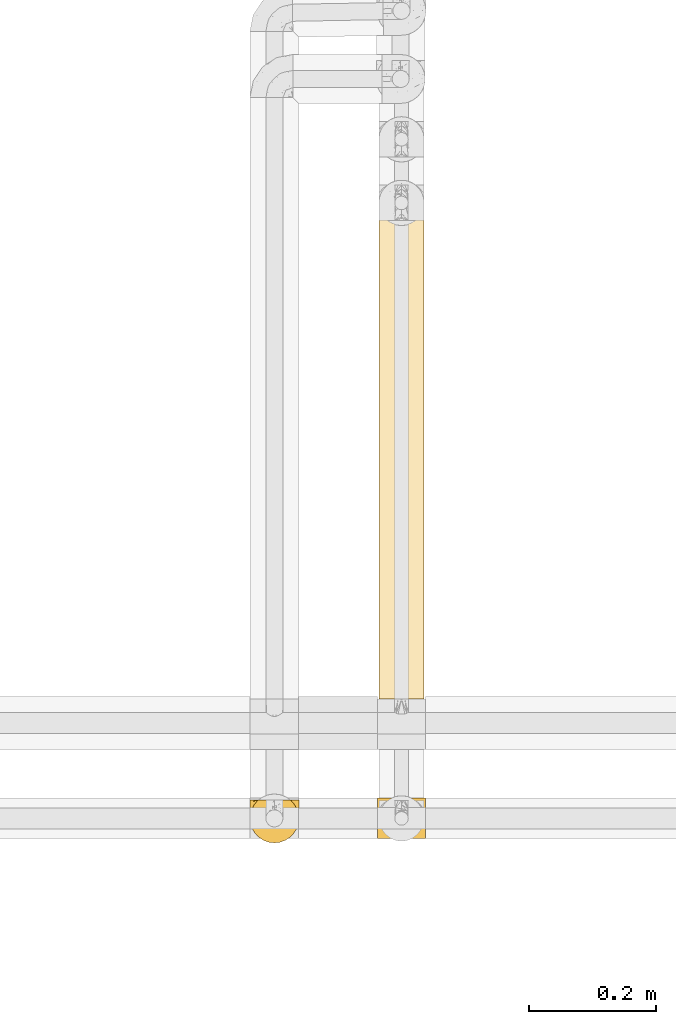
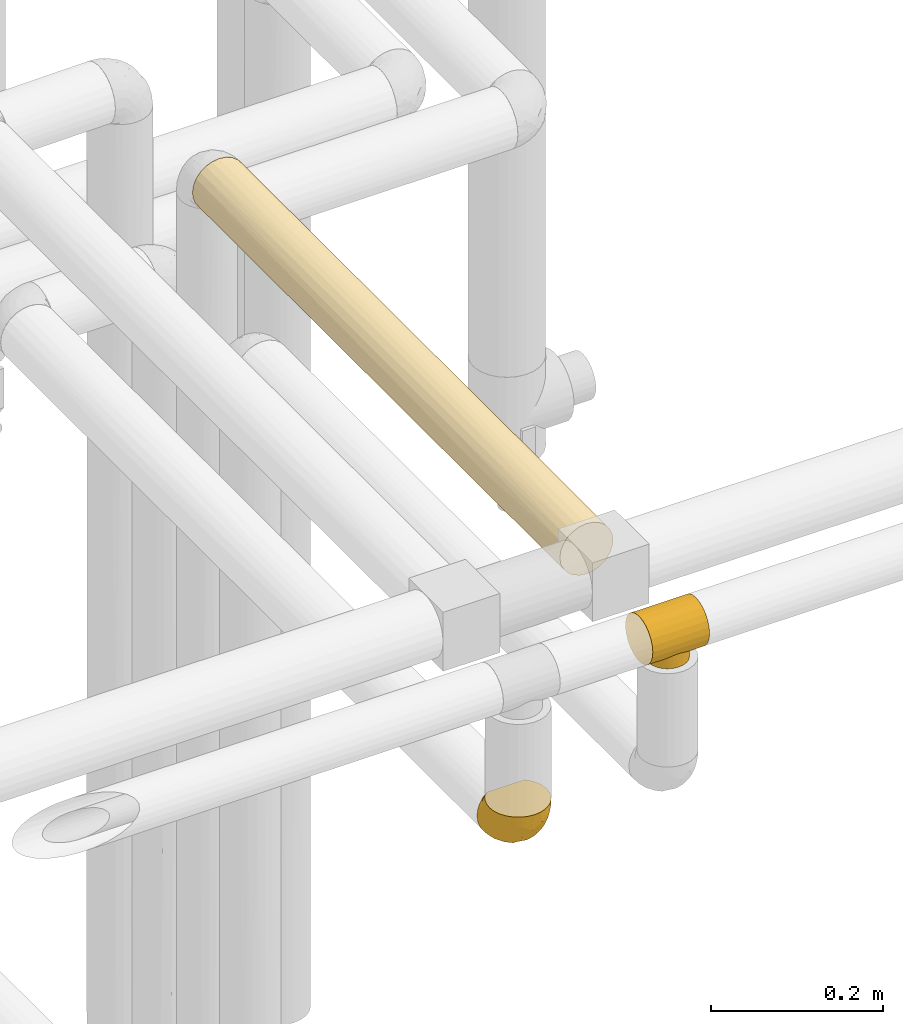
# One storey, part 54 of 827: 3 coverings.
"""IFC2X3 building model written with IfcOpenShell, lengths in millimetres."""

from ifc_helpers import new_model, entity, si_unit, converted_unit, derived_unit, direction, frame, origin, place, context, subcontext, project, spatial, faceted_brep, element, save


model = new_model("IFC2X3")

# Units and contexts
model_context = context("Model", 3, precision=0.01, world=origin(), true_north=direction((6.12303176911189e-17, 1.0)))
body_context = subcontext(model_context, "Body", "Model", "MODEL_VIEW")
ifc_project = project(units=[si_unit("LENGTHUNIT", "METRE", prefix="MILLI"), si_unit("AREAUNIT", "SQUARE_METRE"), si_unit("VOLUMEUNIT", "CUBIC_METRE"), converted_unit("PLANEANGLEUNIT", "DEGREE", entity("IfcRatioMeasure", 0.0174532925199433), si_unit("PLANEANGLEUNIT", "RADIAN"), dimensions=[0, 0, 0, 0, 0, 0, 0]), si_unit("MASSUNIT", "GRAM", prefix="KILO"), derived_unit("MASSDENSITYUNIT", [(si_unit("MASSUNIT", "GRAM", prefix="KILO"), 1), (si_unit("LENGTHUNIT", "METRE"), -3)]), derived_unit("MOMENTOFINERTIAUNIT", [(si_unit("LENGTHUNIT", "METRE"), 4)]), si_unit("TIMEUNIT", "SECOND"), si_unit("FREQUENCYUNIT", "HERTZ"), si_unit("THERMODYNAMICTEMPERATUREUNIT", "DEGREE_CELSIUS"), derived_unit("THERMALTRANSMITTANCEUNIT", [(si_unit("MASSUNIT", "GRAM", prefix="KILO"), 1), (si_unit("THERMODYNAMICTEMPERATUREUNIT", "KELVIN"), -1), (si_unit("TIMEUNIT", "SECOND"), -3)]), derived_unit("VOLUMETRICFLOWRATEUNIT", [(si_unit("LENGTHUNIT", "METRE"), 3), (si_unit("TIMEUNIT", "SECOND"), -1)]), derived_unit("MASSFLOWRATEUNIT", [(si_unit("MASSUNIT", "GRAM", prefix="KILO"), 1), (si_unit("TIMEUNIT", "SECOND"), -1)]), derived_unit("ROTATIONALFREQUENCYUNIT", [(si_unit("TIMEUNIT", "SECOND"), -1)]), si_unit("ELECTRICCURRENTUNIT", "AMPERE"), si_unit("ELECTRICVOLTAGEUNIT", "VOLT"), si_unit("POWERUNIT", "WATT"), si_unit("FORCEUNIT", "NEWTON", prefix="KILO"), si_unit("ILLUMINANCEUNIT", "LUX"), si_unit("LUMINOUSFLUXUNIT", "LUMEN"), si_unit("LUMINOUSINTENSITYUNIT", "CANDELA"), derived_unit("USERDEFINED", [(si_unit("MASSUNIT", "GRAM", prefix="KILO"), -1), (si_unit("LENGTHUNIT", "METRE"), -2), (si_unit("TIMEUNIT", "SECOND"), 3), (si_unit("LUMINOUSFLUXUNIT", "LUMEN"), 1)]), derived_unit("LINEARVELOCITYUNIT", [(si_unit("LENGTHUNIT", "METRE"), 1), (si_unit("TIMEUNIT", "SECOND"), -1)]), si_unit("PRESSUREUNIT", "PASCAL"), derived_unit("USERDEFINED", [(si_unit("LENGTHUNIT", "METRE"), -2), (si_unit("MASSUNIT", "GRAM", prefix="KILO"), 1), (si_unit("TIMEUNIT", "SECOND"), -2)]), derived_unit("LINEARFORCEUNIT", [(si_unit("MASSUNIT", "GRAM", prefix="KILO"), 1), (si_unit("LENGTHUNIT", "METRE"), 1), (si_unit("TIMEUNIT", "SECOND"), -2), (si_unit("LENGTHUNIT", "METRE"), -1)]), derived_unit("PLANARFORCEUNIT", [(si_unit("MASSUNIT", "GRAM", prefix="KILO"), 1), (si_unit("LENGTHUNIT", "METRE"), 1), (si_unit("TIMEUNIT", "SECOND"), -2), (si_unit("LENGTHUNIT", "METRE"), -2)])], contexts=[model_context])

# Site, building, storey
site_placement = place(None, origin())
site = spatial("IfcSite", under=ifc_project, at=site_placement, CompositionType="ELEMENT")
building_placement = place(site_placement, origin())
building = spatial("IfcBuilding", under=site, at=building_placement, CompositionType="ELEMENT")
storey_placement = place(building_placement, frame((0.0, 0.0, 28200.0)))
storey = spatial("IfcBuildingStorey", under=building, at=storey_placement, Name="08", CompositionType="ELEMENT", Elevation=28200.0)

# Coverings
covering_1_placement = place(storey_placement, frame((17890.53, 9559.35, 2812.0)))
element("IfcCovering", 1, at=covering_1_placement, inside=storey, Name=":ADSK_", ObjectType=":ADSK_", PredefinedType="INSULATION", context=body_context, shape_type="Brep", body=[
    faceted_brep([(0.0, 2.68, 46.24), (0.0, 5.86, 53.93), (0.0, 10.92, 60.52), (0.0, 17.52, 65.58), (0.0, 25.2, 68.76), (0.0, 33.45, 69.85), (0.0, 41.69, 68.76), (0.0, 49.37, 65.58), (0.0, 55.97, 60.52), (0.0, 61.03, 53.93), (0.0, 64.21, 46.24), (0.0, 65.3, 38.0), (0.0, 64.21, 29.76), (0.0, 61.03, 22.08), (0.0, 55.97, 15.48), (0.0, 52.67, 12.95), (0.0, 49.37, 10.42), (0.0, 45.53, 8.83), (0.0, 41.69, 7.24), (0.0, 39.63, 6.96), (0.0, 37.57, 6.69), (0.0, 33.45, 6.15), (0.0, 29.32, 6.69), (0.0, 27.26, 6.96), (0.0, 25.2, 7.24), (0.0, 21.36, 8.83), (0.0, 17.52, 10.42), (0.0, 14.22, 12.95), (0.0, 10.92, 15.48), (0.0, 5.86, 22.08), (0.0, 2.68, 29.76), (0.0, 1.6, 38.0), (76.0, 65.3, 38.0), (76.0, 64.21, 46.24), (76.0, 61.03, 53.93), (76.0, 55.97, 60.52), (76.0, 49.37, 65.58), (76.0, 41.69, 68.76), (76.0, 33.45, 69.85), (76.0, 25.2, 68.76), (76.0, 17.52, 65.58), (76.0, 10.92, 60.52), (76.0, 5.86, 53.93), (76.0, 2.68, 46.24), (76.0, 1.6, 38.0), (76.0, 2.68, 29.76), (76.0, 5.86, 22.08), (76.0, 10.92, 15.48), (76.0, 14.22, 12.95), (76.0, 17.52, 10.42), (76.0, 21.36, 8.83), (76.0, 25.2, 7.24), (76.0, 27.26, 6.96), (76.0, 29.32, 6.69), (76.0, 33.45, 6.15), (76.0, 37.57, 6.69), (76.0, 39.63, 6.96), (76.0, 41.69, 7.24), (76.0, 45.53, 8.83), (76.0, 49.37, 10.42), (76.0, 52.67, 12.95), (76.0, 55.97, 15.48), (76.0, 61.03, 22.08), (76.0, 64.21, 29.76), (53.93, 53.55, 13.3), (49.31, 56.47, 15.99), (57.83, 49.71, 10.62), (14.08, 42.23, 7.52), (15.09, 44.99, 8.31), (43.97, 58.39, 18.2), (38.0, 59.1, 19.12), (32.03, 58.39, 18.2), (12.71, 36.46, 6.44), (12.35, 33.45, 6.15), (63.65, 33.45, 6.15), (63.29, 36.46, 6.44), (26.69, 56.47, 15.99), (22.07, 53.55, 13.3), (18.17, 49.71, 10.62), (60.91, 44.99, 8.31), (62.93, 39.47, 6.72), (61.92, 42.23, 7.52), (13.07, 39.47, 6.72), (63.29, 30.43, 6.44), (62.93, 27.42, 6.72), (57.83, 17.18, 10.62), (60.91, 21.9, 8.31), (61.92, 24.66, 7.52), (13.07, 27.42, 6.72), (12.71, 30.43, 6.44), (18.17, 17.18, 10.62), (14.08, 24.66, 7.52), (22.07, 13.34, 13.3), (15.09, 21.9, 8.31), (53.93, 13.34, 13.3), (49.31, 10.42, 15.99), (43.97, 8.5, 18.2), (38.0, 7.8, 19.12), (26.69, 10.42, 15.99), (32.03, 8.5, 18.2), (38.0, 59.1, 0.0), (44.64, 58.22, 0.0), (50.82, 55.66, 0.0), (56.14, 51.58, 0.0), (60.21, 46.27, 0.0), (62.78, 40.08, 0.0), (63.65, 33.45, 0.0), (62.78, 26.81, 0.0), (60.21, 20.62, 0.0), (56.14, 15.31, 0.0), (50.82, 11.23, 0.0), (44.64, 8.67, 0.0), (38.0, 7.8, 0.0), (31.36, 8.67, 0.0), (25.17, 11.23, 0.0), (19.86, 15.31, 0.0), (15.79, 20.62, 0.0), (13.22, 26.81, 0.0), (12.35, 33.45, 0.0), (13.22, 40.08, 0.0), (15.79, 46.27, 0.0), (19.86, 51.58, 0.0), (25.17, 55.66, 0.0), (31.36, 58.22, 0.0)], [[[0, 1, 2, 3, 4, 5, 6, 7, 8, 9, 10, 11, 12, 13, 14, 15, 16, 17, 18, 19, 20, 21, 22, 23, 24, 25, 26, 27, 28, 29, 30, 31]], [[32, 33, 34, 35, 36, 37, 38, 39, 40, 41, 42, 43, 44, 45, 46, 47, 48, 49, 50, 51, 52, 53, 54, 55, 56, 57, 58, 59, 60, 61, 62, 63]], [[36, 35, 8, 7]], [[5, 38, 37, 6]], [[37, 36, 7, 6]], [[9, 34, 33, 10]], [[10, 33, 32, 11]], [[8, 35, 34, 9]], [[63, 12, 11, 32]], [[62, 13, 12, 63]], [[61, 64, 65]], [[60, 59, 66]], [[67, 17, 68]], [[65, 69, 61]], [[64, 61, 60]], [[61, 69, 62]], [[69, 70, 62]], [[71, 14, 13]], [[21, 72, 73]], [[74, 75, 54]], [[76, 14, 71]], [[77, 14, 76]], [[78, 15, 77]], [[71, 13, 70]], [[70, 13, 62]], [[66, 58, 79]], [[59, 58, 66]], [[80, 57, 56, 55]], [[58, 57, 81]], [[17, 67, 18]], [[80, 55, 75]], [[81, 79, 58]], [[20, 82, 72]], [[78, 16, 15]], [[57, 80, 81]], [[78, 17, 16]], [[17, 78, 68]], [[82, 20, 19, 18]], [[77, 15, 14]], [[21, 20, 72]], [[54, 75, 55]], [[82, 18, 67]], [[64, 60, 66]], [[53, 83, 54]], [[84, 53, 52, 51]], [[49, 85, 50]], [[53, 84, 83]], [[86, 50, 85]], [[48, 85, 49]], [[51, 87, 84]], [[88, 24, 23, 22]], [[88, 22, 89]], [[21, 89, 22]], [[89, 21, 73]], [[54, 83, 74]], [[90, 26, 25]], [[24, 91, 25]], [[92, 27, 90]], [[25, 91, 93]], [[85, 48, 94]], [[87, 50, 86]], [[94, 47, 95]], [[47, 94, 48]], [[95, 47, 96]], [[50, 87, 51]], [[29, 46, 45, 30]], [[97, 96, 46]], [[46, 96, 47]], [[45, 44, 31, 30]], [[98, 99, 28]], [[90, 25, 93]], [[27, 26, 90]], [[28, 92, 98]], [[99, 29, 28]], [[24, 88, 91]], [[97, 29, 99]], [[97, 46, 29]], [[92, 28, 27]], [[0, 43, 42, 1]], [[1, 42, 41, 2]], [[44, 43, 0, 31]], [[3, 40, 39, 4]], [[4, 39, 38, 5]], [[2, 41, 40, 3]], [[100, 101, 102, 103, 104, 105, 106, 107, 108, 109, 110, 111, 112, 113, 114, 115, 116, 117, 118, 119, 120, 121, 122, 123]], [[80, 106, 105]], [[79, 105, 104]], [[106, 80, 75, 74]], [[66, 79, 104]], [[105, 79, 81, 80]], [[104, 103, 66]], [[64, 103, 102]], [[101, 100, 69]], [[65, 102, 101]], [[64, 102, 65]], [[69, 65, 101]], [[70, 69, 100]], [[103, 64, 66]], [[71, 100, 123]], [[76, 123, 122]], [[70, 100, 71]], [[71, 123, 76]], [[122, 77, 76]], [[122, 121, 77]], [[78, 121, 120]], [[120, 119, 68]], [[118, 82, 119]], [[68, 78, 120]], [[118, 73, 72, 82]], [[119, 82, 67, 68]], [[121, 78, 77]], [[88, 118, 117]], [[93, 117, 116]], [[118, 88, 89, 73]], [[90, 93, 116]], [[117, 93, 91, 88]], [[116, 115, 90]], [[92, 115, 114]], [[114, 113, 98]], [[112, 99, 113]], [[92, 114, 98]], [[99, 98, 113]], [[97, 99, 112]], [[115, 92, 90]], [[96, 112, 111]], [[95, 111, 110]], [[97, 112, 96]], [[96, 111, 95]], [[110, 94, 95]], [[110, 109, 94]], [[85, 109, 108]], [[108, 107, 86]], [[106, 84, 107]], [[86, 85, 108]], [[106, 74, 83, 84]], [[107, 84, 87, 86]], [[109, 85, 94]]]),
])
covering_2_placement = place(storey_placement, frame((17688.48, 9552.75, 2611.68)))
element("IfcCovering", 2, at=covering_2_placement, inside=storey, Name=":ADSK_", ObjectType=":ADSK_", PredefinedType="INSULATION", context=body_context, shape_type="Brep", body=[
    faceted_brep([(5.41, 23.36, 69.15), (9.99, 16.07, 69.15), (16.08, 9.98, 69.15), (23.37, 5.4, 69.15), (31.49, 2.56, 69.15), (40.05, 1.6, 69.15), (48.61, 2.56, 69.15), (56.73, 5.41, 69.15), (64.02, 9.99, 69.15), (70.11, 16.08, 69.15), (74.69, 23.37, 69.15), (77.53, 31.49, 69.15), (78.5, 40.05, 69.15), (77.63, 48.15, 69.15), (75.08, 55.88, 69.15), (70.97, 62.9, 69.15), (65.47, 68.89, 69.15), (63.27, 68.89, 69.15), (61.53, 68.89, 69.15), (59.57, 68.89, 69.15), (57.6, 68.89, 69.15), (55.63, 68.89, 69.15), (53.67, 68.89, 69.15), (51.7, 68.89, 69.15), (49.73, 68.89, 69.15), (47.54, 68.89, 69.15), (45.34, 68.89, 69.15), (43.15, 68.89, 69.15), (40.96, 68.89, 69.15), (38.76, 68.89, 69.15), (36.57, 68.89, 69.15), (34.37, 68.89, 69.15), (32.18, 68.89, 69.15), (29.98, 68.89, 69.15), (27.79, 68.89, 69.15), (25.6, 68.89, 69.15), (23.4, 68.89, 69.15), (21.21, 68.89, 69.15), (19.01, 68.89, 69.15), (16.82, 68.89, 69.15), (14.62, 68.89, 69.15), (9.12, 62.89, 69.15), (5.0, 55.86, 69.15), (2.46, 48.13, 69.15), (1.6, 40.05, 69.15), (2.56, 31.49, 69.15), (65.47, 69.15, 68.89), (70.97, 69.15, 62.89), (75.09, 69.15, 55.87), (77.63, 69.15, 48.14), (78.5, 69.15, 40.05), (77.19, 69.15, 30.09), (73.34, 69.15, 20.82), (67.23, 69.15, 12.86), (59.27, 69.15, 6.75), (50.0, 69.15, 2.91), (40.05, 69.15, 1.6), (30.09, 69.15, 2.91), (20.82, 69.15, 6.75), (12.86, 69.15, 12.86), (6.75, 69.15, 20.82), (2.91, 69.15, 30.09), (1.6, 69.15, 40.05), (2.46, 69.15, 48.14), (5.0, 69.15, 55.87), (9.12, 69.15, 62.89), (14.62, 69.15, 68.89), (16.82, 69.15, 68.89), (17.8, 69.15, 68.89), (19.39, 69.15, 68.89), (20.98, 69.15, 68.89), (22.57, 69.15, 68.89), (24.16, 69.15, 68.89), (25.75, 69.15, 68.89), (27.33, 69.15, 68.89), (28.92, 69.15, 68.89), (30.51, 69.15, 68.89), (32.1, 69.15, 68.89), (33.69, 69.15, 68.89), (35.28, 69.15, 68.89), (36.87, 69.15, 68.89), (38.46, 69.15, 68.89), (40.05, 69.15, 68.89), (41.63, 69.15, 68.89), (43.22, 69.15, 68.89), (44.81, 69.15, 68.89), (46.4, 69.15, 68.89), (47.99, 69.15, 68.89), (49.58, 69.15, 68.89), (51.17, 69.15, 68.89), (52.76, 69.15, 68.89), (54.72, 69.15, 68.89), (56.69, 69.15, 68.89), (58.88, 69.15, 68.89), (61.08, 69.15, 68.89), (63.27, 69.15, 68.89), (37.77, 68.96, 68.97), (36.07, 68.97, 68.96), (32.96, 68.97, 68.97), (31.36, 68.97, 68.97), (56.52, 68.95, 68.98), (54.96, 68.96, 68.97), (18.75, 68.98, 68.96), (58.07, 68.97, 68.96), (50.37, 68.97, 68.96), (23.36, 68.98, 68.96), (24.95, 68.97, 68.96), (42.43, 68.97, 68.96), (15.97, 68.94, 69.0), (51.96, 68.98, 68.96), (53.47, 68.98, 68.96), (48.63, 68.96, 68.97), (63.93, 68.97, 68.96), (40.93, 68.98, 68.96), (29.72, 68.98, 68.96), (62.4, 68.97, 68.97), (60.92, 68.96, 68.97), (17.31, 68.97, 68.97), (21.74, 68.97, 68.96), (34.56, 68.98, 68.96), (20.18, 68.96, 68.97), (14.62, 68.97, 68.97), (14.62, 68.94, 69.02), (14.62, 68.92, 69.08), (65.47, 68.97, 68.97), (65.47, 69.02, 68.94), (65.47, 69.08, 68.92), (59.5, 68.98, 68.96), (47.1, 68.97, 68.96), (45.61, 68.98, 68.95), (28.18, 68.97, 68.96), (14.62, 69.08, 68.92), (14.62, 69.02, 68.94), (26.61, 68.96, 68.98), (65.47, 68.92, 69.08), (65.47, 68.94, 69.02), (39.32, 68.97, 68.96), (44.12, 68.96, 68.97), (72.26, 67.02, 61.33), (76.57, 63.33, 53.1), (71.77, 64.61, 63.33), (78.5, 49.27, 49.27), (77.9, 51.4, 55.53), (78.5, 43.94, 54.6), (78.5, 61.87, 41.99), (75.52, 61.54, 57.07), (76.13, 57.95, 57.95), (77.81, 56.12, 51.56), (78.5, 63.4, 41.58), (72.4, 65.41, 61.7), (76.56, 53.1, 63.33), (71.77, 63.04, 65.0), (72.25, 61.33, 67.02), (78.5, 41.99, 61.87), (78.5, 54.6, 43.94), (75.75, 56.6, 61.21), (78.5, 41.58, 63.4), (50.46, 13.72, 33.11), (52.75, 5.82, 52.82), (40.05, 6.74, 43.3), (77.7, 58.82, 33.73), (77.66, 51.58, 36.52), (71.02, 42.09, 24.87), (63.45, 46.12, 14.17), (70.55, 55.56, 18.43), (75.57, 52.38, 28.67), (75.57, 61.54, 26.0), (72.61, 23.76, 49.25), (72.61, 20.5, 59.72), (67.24, 14.64, 55.1), (77.74, 41.77, 44.72), (57.43, 16.28, 34.15), (47.19, 49.4, 5.25), (54.76, 52.34, 6.75), (40.05, 4.3, 55.54), (63.45, 58.67, 10.47), (60.1, 25.26, 25.49), (63.72, 20.17, 35.53), (76.83, 34.7, 48.22), (76.34, 28.67, 58.71), (60.51, 8.62, 57.42), (72.59, 33.37, 34.84), (76.05, 41.35, 36.87), (66.15, 17.15, 45.01), (60.51, 12.68, 44.4), (51.88, 21.47, 23.96), (55.34, 41.11, 11.2), (48.67, 37.53, 10.56), (53.89, 30.64, 16.81), (46.73, 26.66, 17.38), (40.05, 21.38, 21.38), (40.05, 14.06, 32.34), (40.05, 55.54, 4.3), (63.95, 35.17, 20.65), (67.24, 29.04, 29.66), (69.62, 24.34, 39.6), (73.6, 29.33, 42.55), (40.05, 43.3, 6.74), (40.05, 32.34, 14.06), (4.52, 57.75, 26.84), (32.72, 49.41, 5.28), (27.18, 27.85, 18.52), (29.63, 13.7, 33.13), (12.86, 14.63, 55.1), (19.59, 8.61, 57.43), (9.54, 48.85, 20.72), (16.64, 54.13, 11.46), (17.48, 37.84, 17.69), (7.49, 23.75, 49.26), (7.49, 20.49, 59.73), (3.75, 28.66, 58.71), (20.75, 20.83, 29.72), (2.33, 55.15, 35.35), (1.6, 54.6, 43.94), (1.6, 61.87, 41.99), (1.6, 41.58, 63.4), (26.94, 57.58, 4.93), (9.54, 59.91, 17.46), (31.21, 36.94, 10.94), (25.33, 45.72, 8.92), (27.35, 5.82, 52.83), (8.17, 37.91, 29.34), (4.3, 50.18, 30.26), (19.59, 12.67, 44.4), (2.23, 49.29, 39.06), (2.45, 42.64, 43.06), (1.6, 43.94, 54.6), (1.6, 49.27, 49.27), (12.86, 19.45, 42.69), (3.27, 34.7, 48.2), (1.6, 41.99, 61.87), (2.29, 62.29, 33.44), (12.86, 29.01, 29.67), (6.89, 31.47, 38.5), (12.43, 37.18, 23.35), (4.1, 43.45, 34.97), (3.53, 63.33, 53.1), (6.88, 67.23, 59.68), (8.16, 66.07, 62.19), (9.02, 65.22, 64.11), (5.0, 61.99, 57.97), (3.96, 57.95, 57.95), (3.52, 53.09, 63.33), (2.4, 56.84, 51.77), (7.83, 61.33, 67.02), (8.32, 63.06, 64.98), (2.19, 51.41, 55.53), (4.34, 56.61, 61.22)], [[[0, 1, 2, 3, 4, 5, 6, 7, 8, 9, 10, 11, 12, 13, 14, 15, 16, 17, 18, 19, 20, 21, 22, 23, 24, 25, 26, 27, 28, 29, 30, 31, 32, 33, 34, 35, 36, 37, 38, 39, 40, 41, 42, 43, 44, 45]], [[46, 47, 48, 49, 50, 51, 52, 53, 54, 55, 56, 57, 58, 59, 60, 61, 62, 63, 64, 65, 66, 67, 68, 69, 70, 71, 72, 73, 74, 75, 76, 77, 78, 79, 80, 81, 82, 83, 84, 85, 86, 87, 88, 89, 90, 91, 92, 93, 94, 95]], [[96, 97, 30]], [[98, 77, 99]], [[100, 101, 21]], [[69, 68, 102]], [[20, 19, 103]], [[24, 23, 104]], [[20, 103, 100]], [[72, 105, 106]], [[84, 83, 107]], [[89, 88, 104]], [[108, 67, 66]], [[109, 110, 90]], [[111, 25, 24]], [[112, 17, 16]], [[82, 113, 83]], [[109, 23, 22]], [[114, 76, 75]], [[105, 36, 106]], [[104, 111, 24]], [[18, 115, 116]], [[97, 96, 80]], [[67, 108, 117]], [[105, 71, 118]], [[31, 97, 119]], [[102, 120, 69]], [[108, 121, 122, 123, 40]], [[112, 95, 115]], [[17, 115, 18]], [[94, 116, 115]], [[117, 68, 67]], [[38, 117, 39]], [[112, 124, 125, 126, 46]], [[17, 112, 115]], [[70, 120, 118]], [[39, 117, 108]], [[120, 38, 37]], [[120, 37, 118]], [[120, 70, 69]], [[116, 94, 127]], [[128, 86, 129]], [[117, 38, 102]], [[74, 130, 75]], [[99, 33, 32]], [[115, 95, 94]], [[39, 108, 40]], [[108, 66, 131, 132, 121]], [[105, 72, 71]], [[118, 37, 36]], [[71, 70, 118]], [[35, 106, 36]], [[36, 105, 118]], [[35, 133, 106]], [[74, 73, 133]], [[106, 133, 73]], [[99, 114, 33]], [[133, 35, 34]], [[73, 72, 106]], [[95, 112, 46]], [[112, 16, 134, 135, 124]], [[130, 114, 75]], [[99, 76, 114]], [[114, 130, 33]], [[34, 33, 130]], [[78, 77, 98]], [[98, 119, 78]], [[130, 133, 34]], [[133, 130, 74]], [[79, 97, 80]], [[98, 99, 32]], [[98, 32, 31]], [[77, 76, 99]], [[97, 79, 119]], [[136, 96, 29]], [[30, 97, 31]], [[136, 29, 28]], [[81, 80, 96]], [[29, 96, 30]], [[31, 119, 98]], [[119, 79, 78]], [[96, 136, 81]], [[82, 81, 136]], [[113, 107, 83]], [[84, 107, 137]], [[107, 27, 137]], [[113, 28, 107]], [[27, 107, 28]], [[85, 84, 137]], [[137, 27, 26]], [[113, 136, 28]], [[136, 113, 82]], [[109, 89, 104]], [[86, 85, 129]], [[89, 109, 90]], [[111, 87, 128]], [[26, 129, 137]], [[88, 111, 104]], [[25, 111, 128]], [[22, 110, 109]], [[23, 109, 104]], [[110, 91, 90]], [[100, 92, 101]], [[110, 22, 101]], [[91, 110, 101]], [[116, 19, 18]], [[111, 88, 87]], [[127, 103, 19]], [[25, 128, 26]], [[86, 128, 87]], [[128, 129, 26]], [[137, 129, 85]], [[120, 102, 38]], [[117, 102, 68]], [[91, 101, 92]], [[21, 101, 22]], [[93, 92, 103]], [[100, 21, 20]], [[100, 103, 92]], [[127, 93, 103]], [[93, 127, 94]], [[116, 127, 19]], [[126, 138, 47]], [[48, 138, 139]], [[140, 125, 124]], [[141, 142, 143]], [[144, 49, 139]], [[145, 140, 146]], [[48, 139, 49]], [[139, 145, 147]], [[49, 144, 148, 50]], [[126, 125, 149]], [[14, 13, 150]], [[151, 146, 140]], [[149, 140, 145]], [[152, 151, 135]], [[152, 14, 150]], [[16, 15, 134]], [[13, 153, 150]], [[124, 151, 140]], [[141, 147, 142]], [[14, 152, 15]], [[15, 152, 134]], [[47, 46, 126]], [[139, 154, 144]], [[138, 48, 47]], [[125, 140, 149]], [[135, 134, 152]], [[146, 155, 142]], [[145, 146, 147]], [[149, 139, 138]], [[147, 141, 154]], [[147, 146, 142]], [[139, 147, 154]], [[139, 149, 145]], [[149, 138, 126]], [[155, 146, 151]], [[150, 143, 142]], [[152, 155, 151]], [[150, 142, 155]], [[13, 12, 156, 153]], [[153, 143, 150]], [[152, 150, 155]], [[151, 124, 135]], [[157, 158, 159]], [[160, 154, 161]], [[162, 163, 164]], [[165, 166, 160]], [[167, 168, 169]], [[141, 170, 161]], [[156, 12, 11]], [[158, 157, 171]], [[172, 55, 173]], [[158, 6, 174]], [[175, 54, 53]], [[52, 166, 164]], [[52, 164, 53]], [[54, 175, 173]], [[166, 52, 51]], [[176, 177, 171]], [[178, 143, 179]], [[156, 11, 179]], [[8, 7, 180]], [[169, 9, 8]], [[179, 143, 153, 156]], [[179, 11, 10]], [[168, 179, 10]], [[181, 162, 182]], [[179, 167, 178]], [[183, 184, 177]], [[183, 169, 184]], [[176, 171, 185]], [[172, 186, 187]], [[158, 7, 6]], [[159, 158, 174]], [[184, 180, 158]], [[54, 173, 55]], [[180, 169, 8]], [[188, 189, 187]], [[9, 168, 10]], [[186, 188, 187]], [[190, 157, 159, 191]], [[55, 172, 192]], [[176, 193, 194]], [[161, 170, 182]], [[162, 164, 165]], [[175, 164, 163]], [[51, 50, 148]], [[167, 195, 196]], [[178, 182, 170]], [[6, 5, 174]], [[158, 180, 7]], [[169, 180, 184]], [[169, 168, 9]], [[179, 168, 167]], [[182, 162, 165]], [[162, 194, 193]], [[161, 165, 160]], [[195, 181, 196]], [[192, 172, 197]], [[192, 56, 55]], [[189, 190, 198]], [[198, 197, 187]], [[172, 187, 197]], [[185, 189, 188]], [[198, 187, 189]], [[186, 172, 173]], [[173, 163, 186]], [[193, 186, 163]], [[176, 185, 188]], [[185, 157, 190]], [[188, 186, 193]], [[177, 176, 194]], [[188, 193, 176]], [[162, 193, 163]], [[195, 177, 194]], [[171, 177, 184]], [[181, 195, 194]], [[183, 167, 169]], [[162, 181, 194]], [[196, 182, 178]], [[158, 171, 184]], [[171, 157, 185]], [[177, 195, 183]], [[167, 183, 195]], [[182, 196, 181]], [[178, 170, 143]], [[178, 167, 196]], [[164, 175, 53]], [[173, 175, 163]], [[160, 51, 148]], [[164, 166, 165]], [[51, 160, 166]], [[160, 148, 144, 154]], [[141, 161, 154]], [[182, 165, 161]], [[190, 189, 185]], [[143, 170, 141]], [[60, 199, 61]], [[197, 200, 192]], [[201, 190, 202]], [[200, 57, 192]], [[203, 204, 2]], [[205, 206, 207]], [[208, 209, 210]], [[211, 207, 201]], [[212, 213, 214]], [[45, 215, 210]], [[216, 206, 58]], [[45, 44, 215]], [[59, 217, 60]], [[60, 217, 199]], [[0, 45, 210]], [[218, 201, 219]], [[202, 159, 220]], [[205, 221, 222]], [[223, 204, 203]], [[1, 203, 2]], [[57, 200, 216]], [[220, 3, 204]], [[220, 174, 4]], [[1, 0, 209]], [[212, 224, 213]], [[225, 226, 227]], [[228, 223, 203]], [[208, 210, 229]], [[210, 226, 229]], [[3, 220, 4]], [[58, 206, 59]], [[209, 203, 1]], [[202, 220, 223]], [[228, 203, 208]], [[202, 211, 201]], [[3, 2, 204]], [[202, 190, 191, 159]], [[210, 215, 230, 226]], [[199, 212, 231]], [[232, 233, 221]], [[233, 208, 229]], [[207, 206, 219]], [[217, 206, 205]], [[227, 224, 225]], [[233, 232, 228]], [[201, 207, 219]], [[234, 232, 221]], [[218, 219, 200]], [[202, 223, 211]], [[174, 220, 159]], [[174, 5, 4]], [[61, 231, 62]], [[220, 204, 223]], [[210, 209, 0]], [[203, 209, 208]], [[225, 233, 229]], [[224, 227, 213]], [[221, 233, 235]], [[57, 56, 192]], [[198, 218, 197]], [[200, 219, 216]], [[201, 198, 190]], [[197, 218, 200]], [[198, 201, 218]], [[206, 216, 219]], [[58, 57, 216]], [[231, 212, 214]], [[222, 212, 199]], [[228, 211, 223]], [[207, 211, 232]], [[62, 231, 214]], [[199, 231, 61]], [[233, 228, 208]], [[211, 228, 232]], [[222, 221, 235]], [[234, 205, 207]], [[206, 217, 59]], [[199, 217, 205]], [[205, 222, 199]], [[224, 222, 235]], [[222, 224, 212]], [[224, 235, 225]], [[233, 225, 235]], [[226, 225, 229]], [[205, 234, 221]], [[207, 232, 234]], [[63, 214, 236]], [[214, 213, 236]], [[214, 63, 62]], [[237, 236, 238]], [[238, 132, 131]], [[236, 237, 64]], [[239, 240, 241]], [[63, 236, 64]], [[131, 66, 65]], [[237, 131, 65]], [[242, 230, 43]], [[237, 65, 64]], [[239, 121, 132]], [[42, 242, 43]], [[241, 240, 243]], [[41, 123, 244]], [[43, 230, 215, 44]], [[244, 122, 245]], [[227, 246, 243]], [[241, 247, 245]], [[121, 239, 245]], [[41, 40, 123]], [[132, 238, 239]], [[244, 42, 41]], [[131, 237, 238]], [[240, 239, 238]], [[245, 239, 241]], [[247, 241, 246]], [[247, 244, 245]], [[238, 236, 240]], [[243, 236, 213]], [[236, 243, 240]], [[227, 226, 246]], [[243, 213, 227]], [[242, 246, 226]], [[243, 246, 241]], [[246, 242, 247]], [[244, 247, 242]], [[242, 226, 230]], [[42, 244, 242]], [[122, 244, 123]], [[122, 121, 245]]]),
])
covering_3_placement = place(storey_placement, frame((17891.28, 9780.79, 2812.79)))
element("IfcCovering", 3, at=covering_3_placement, inside=storey, Name=":ADSK_", ObjectType=":ADSK_", PredefinedType="INSULATION", context=body_context, shape_type="Brep", body=[
    faceted_brep([(28.02, 0.01, 2.81), (37.25, 0.01, 1.6), (46.47, 0.01, 2.81), (55.07, 0.01, 6.37), (62.45, 0.01, 12.04), (68.12, 0.01, 19.42), (71.68, 0.01, 28.02), (72.9, 0.0, 37.25), (71.68, 0.0, 46.47), (68.12, 0.0, 55.07), (62.45, 0.0, 62.45), (55.07, 0.0, 68.12), (46.47, 0.0, 71.68), (37.25, 0.0, 72.9), (28.02, 0.0, 71.68), (19.42, 0.0, 68.12), (12.04, 0.0, 62.45), (6.37, 0.0, 55.07), (2.81, 0.0, 46.47), (1.6, 0.0, 37.25), (2.81, 0.01, 28.02), (6.37, 0.01, 19.42), (12.04, 0.01, 12.04), (19.42, 0.01, 6.37), (15.18, 852.41, 9.34), (9.47, 852.41, 14.99), (5.17, 852.41, 21.78), (2.5, 852.41, 29.35), (1.6, 852.41, 37.34), (2.81, 852.41, 46.57), (6.37, 852.4, 55.17), (12.04, 852.4, 62.55), (19.42, 852.4, 68.22), (28.02, 852.4, 71.78), (37.25, 852.4, 72.99), (46.47, 852.4, 71.78), (55.07, 852.4, 68.22), (62.45, 852.4, 62.55), (68.12, 852.4, 55.17), (71.68, 852.41, 46.57), (72.9, 852.41, 37.34), (71.99, 852.41, 29.35), (69.32, 852.41, 21.78), (65.02, 852.41, 14.99), (59.31, 852.41, 9.34), (7.13, 663.98, 18.24), (3.62, 598.32, 25.46), (17.04, 209.1, 7.9), (11.55, 275.32, 12.56), (11.79, 541.2, 12.35), (31.32, 845.25, 2.19), (37.25, 636.28, 1.67), (28.33, 565.14, 2.79), (37.25, 208.49, 1.62), (1.6, 643.93, 37.32), (7.13, 442.72, 18.22), (17.48, 647.48, 7.65), (17.35, 426.85, 7.71), (1.6, 217.72, 37.27), (3.26, 298.3, 26.52), (20.14, 849.13, 6.07), (25.57, 846.73, 3.66), (1.6, 435.44, 37.29), (37.25, 427.8, 1.64), (30.55, 318.14, 2.27), (23.6, 241.31, 4.34), (6.96, 220.2, 18.46), (37.25, 844.76, 1.69), (1.6, 208.49, 37.27), (43.17, 845.25, 2.19), (48.92, 846.73, 3.66), (46.16, 565.14, 2.79), (50.89, 241.31, 4.34), (57.14, 426.85, 7.71), (57.45, 209.1, 7.9), (57.01, 647.48, 7.65), (54.36, 849.13, 6.07), (62.7, 541.2, 12.35), (67.36, 663.98, 18.24), (43.94, 318.14, 2.27), (71.23, 298.3, 26.52), (72.9, 217.72, 37.27), (67.53, 220.2, 18.46), (62.94, 275.32, 12.56), (67.36, 442.72, 18.22), (70.87, 598.32, 25.46), (72.9, 435.44, 37.29), (72.9, 416.97, 37.29), (72.9, 208.49, 37.27), (72.9, 643.93, 37.32), (65.53, 426.2, 59.0), (65.53, 191.89, 58.97), (70.18, 276.75, 50.92), (70.18, 580.29, 50.95), (65.53, 660.52, 59.02), (58.95, 262.59, 65.56), (72.29, 314.1, 43.85), (72.29, 530.45, 43.82), (58.95, 575.66, 65.59), (50.89, 383.84, 70.23), (45.12, 587.31, 72.08), (43.82, 321.96, 72.32), (52.4, 601.42, 69.58), (48.98, 188.97, 70.93), (37.25, 643.92, 72.97), (37.25, 208.48, 72.92), (37.25, 435.44, 72.94), (37.25, 416.97, 72.94), (15.54, 426.2, 65.58), (15.54, 191.89, 65.55), (23.6, 276.75, 70.21), (23.6, 580.28, 70.25), (15.54, 660.52, 65.6), (8.96, 262.59, 58.98), (30.68, 314.1, 72.32), (30.73, 530.44, 72.35), (8.96, 575.66, 59.01), (4.31, 383.85, 50.93), (2.48, 587.32, 45.19), (2.21, 321.96, 43.85), (4.98, 601.42, 52.47), (3.58, 188.98, 49.0)], [[[0, 1, 2, 3, 4, 5, 6, 7, 8, 9, 10, 11, 12, 13, 14, 15, 16, 17, 18, 19, 20, 21, 22, 23]], [[24, 25, 26, 27, 28, 29, 30, 31, 32, 33, 34, 35, 36, 37, 38, 39, 40, 41, 42, 43, 44]], [[45, 46, 26]], [[47, 22, 48]], [[24, 49, 25]], [[50, 51, 52]], [[1, 0, 53]], [[28, 27, 54]], [[46, 54, 27]], [[55, 49, 48]], [[56, 57, 49]], [[20, 58, 59]], [[25, 45, 26]], [[56, 60, 61]], [[49, 24, 56]], [[52, 57, 56]], [[24, 60, 56]], [[52, 61, 50]], [[26, 46, 27]], [[56, 61, 52]], [[21, 20, 59]], [[46, 62, 54]], [[59, 62, 46]], [[48, 57, 47]], [[49, 55, 45]], [[63, 53, 64]], [[65, 0, 23]], [[48, 49, 57]], [[57, 65, 47]], [[48, 66, 55]], [[66, 22, 21]], [[59, 46, 55]], [[59, 55, 66]], [[57, 52, 65]], [[52, 63, 64]], [[49, 45, 25]], [[46, 45, 55]], [[64, 0, 65]], [[0, 64, 53]], [[52, 64, 65]], [[22, 66, 48]], [[59, 66, 21]], [[65, 23, 47]], [[22, 47, 23]], [[51, 50, 67]], [[51, 63, 52]], [[20, 19, 68, 58]], [[58, 62, 59]], [[69, 51, 67]], [[69, 70, 71]], [[72, 73, 74]], [[2, 72, 3]], [[70, 75, 71]], [[75, 76, 44]], [[69, 71, 51]], [[74, 4, 3]], [[73, 75, 77]], [[77, 43, 78]], [[63, 79, 53]], [[80, 81, 6]], [[71, 79, 63]], [[82, 83, 84]], [[42, 41, 85]], [[77, 75, 44]], [[78, 85, 84]], [[80, 86, 87, 81]], [[6, 81, 88, 7]], [[82, 80, 5]], [[75, 70, 76]], [[80, 85, 86]], [[77, 44, 43]], [[77, 83, 73]], [[85, 80, 84]], [[83, 74, 73]], [[71, 75, 73]], [[78, 43, 42]], [[83, 77, 84]], [[82, 4, 83]], [[41, 89, 85]], [[5, 80, 6]], [[53, 79, 2]], [[71, 73, 72]], [[85, 78, 42]], [[77, 78, 84]], [[2, 1, 53]], [[71, 72, 79]], [[2, 79, 72]], [[80, 82, 84]], [[4, 82, 5]], [[4, 74, 83]], [[3, 72, 74]], [[71, 63, 51]], [[89, 41, 40]], [[89, 86, 85]], [[90, 91, 92, 93, 94]], [[91, 95, 10]], [[96, 97, 92]], [[38, 93, 39]], [[97, 87, 86, 89]], [[37, 94, 38]], [[8, 88, 96]], [[91, 10, 9]], [[9, 8, 92]], [[36, 98, 37]], [[98, 95, 91, 90, 94]], [[99, 100, 101]], [[99, 102, 100]], [[40, 39, 89]], [[88, 8, 7]], [[103, 99, 101]], [[99, 103, 95]], [[11, 10, 95]], [[102, 35, 100]], [[35, 104, 100]], [[105, 13, 12]], [[104, 35, 34]], [[87, 97, 96]], [[95, 98, 99]], [[93, 38, 94]], [[12, 103, 101]], [[97, 39, 93]], [[39, 97, 89]], [[92, 97, 93]], [[92, 8, 96]], [[12, 101, 105]], [[96, 88, 81, 87]], [[101, 106, 107, 105]], [[102, 99, 98]], [[106, 101, 100]], [[12, 11, 103]], [[95, 103, 11]], [[92, 91, 9]], [[98, 94, 37]], [[98, 36, 102]], [[35, 102, 36]], [[104, 106, 100]], [[108, 109, 110, 111, 112]], [[109, 113, 16]], [[114, 115, 110]], [[32, 111, 33]], [[115, 107, 106, 104]], [[31, 112, 32]], [[14, 105, 114]], [[109, 16, 15]], [[15, 14, 110]], [[30, 116, 31]], [[116, 113, 109, 108, 112]], [[117, 118, 119]], [[117, 120, 118]], [[34, 33, 104]], [[105, 14, 13]], [[121, 117, 119]], [[117, 121, 113]], [[17, 16, 113]], [[120, 29, 118]], [[29, 54, 118]], [[68, 19, 18]], [[54, 29, 28]], [[107, 115, 114]], [[113, 116, 117]], [[111, 32, 112]], [[18, 121, 119]], [[115, 33, 111]], [[33, 115, 104]], [[110, 115, 111]], [[110, 14, 114]], [[18, 119, 68]], [[105, 107, 114]], [[119, 62, 58, 68]], [[120, 117, 116]], [[62, 119, 118]], [[18, 17, 121]], [[113, 121, 17]], [[110, 109, 15]], [[116, 112, 31]], [[116, 30, 120]], [[29, 120, 30]], [[54, 62, 118]], [[76, 70, 69, 67, 50, 61, 60, 24, 44]]]),
])

save(model, "model.ifc")
